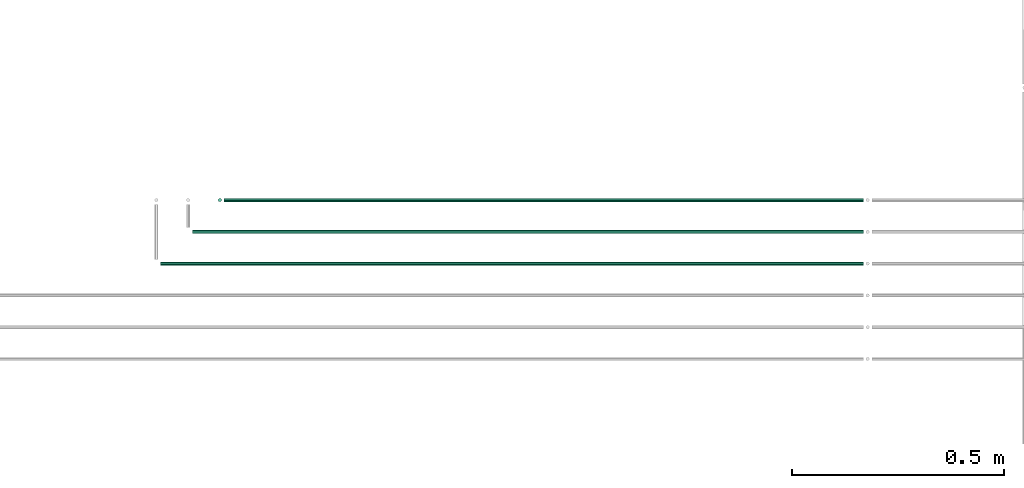
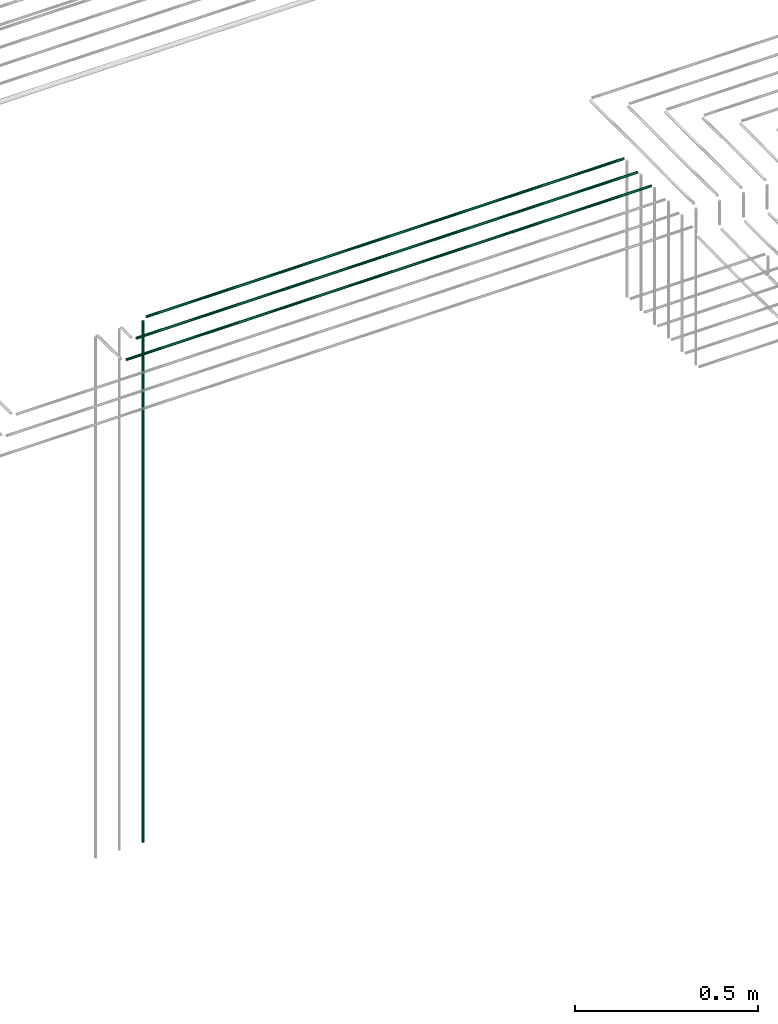
# One storey, part 23 of 89: 4 flow segments.
"""IFC2X3 building model written with IfcOpenShell, lengths in millimetres."""

from ifc_helpers import new_model, entity, si_unit, converted_unit, derived_unit, direction, frame, frame_2d, origin, origin_2d_with_axis, place, context, subcontext, project, spatial, circle, extrude, type_object, element, save


model = new_model("IFC2X3")

# Units and contexts
model_context = context("Model", 3, precision=0.01, world=origin(), true_north=direction((6.12303176911189e-17, 1.0)))
body_context = subcontext(model_context, "Body", "Model", "MODEL_VIEW")
ifc_project = project(units=[si_unit("LENGTHUNIT", "METRE", prefix="MILLI"), si_unit("AREAUNIT", "SQUARE_METRE"), si_unit("VOLUMEUNIT", "CUBIC_METRE"), converted_unit("PLANEANGLEUNIT", "DEGREE", entity("IfcRatioMeasure", 0.0174532925199433), si_unit("PLANEANGLEUNIT", "RADIAN"), dimensions=[0, 0, 0, 0, 0, 0, 0]), si_unit("MASSUNIT", "GRAM", prefix="KILO"), derived_unit("MASSDENSITYUNIT", [(si_unit("MASSUNIT", "GRAM", prefix="KILO"), 1), (si_unit("LENGTHUNIT", "METRE"), -3)]), derived_unit("MOMENTOFINERTIAUNIT", [(si_unit("LENGTHUNIT", "METRE"), 4)]), si_unit("TIMEUNIT", "SECOND"), si_unit("FREQUENCYUNIT", "HERTZ"), si_unit("THERMODYNAMICTEMPERATUREUNIT", "DEGREE_CELSIUS"), derived_unit("THERMALTRANSMITTANCEUNIT", [(si_unit("MASSUNIT", "GRAM", prefix="KILO"), 1), (si_unit("THERMODYNAMICTEMPERATUREUNIT", "KELVIN"), -1), (si_unit("TIMEUNIT", "SECOND"), -3)]), derived_unit("VOLUMETRICFLOWRATEUNIT", [(si_unit("LENGTHUNIT", "METRE"), 3), (si_unit("TIMEUNIT", "SECOND"), -1)]), derived_unit("MASSFLOWRATEUNIT", [(si_unit("MASSUNIT", "GRAM", prefix="KILO"), 1), (si_unit("TIMEUNIT", "SECOND"), -1)]), derived_unit("ROTATIONALFREQUENCYUNIT", [(si_unit("TIMEUNIT", "SECOND"), -1)]), si_unit("ELECTRICCURRENTUNIT", "AMPERE"), si_unit("ELECTRICVOLTAGEUNIT", "VOLT"), si_unit("POWERUNIT", "WATT"), si_unit("FORCEUNIT", "NEWTON", prefix="KILO"), si_unit("ILLUMINANCEUNIT", "LUX"), si_unit("LUMINOUSFLUXUNIT", "LUMEN"), si_unit("LUMINOUSINTENSITYUNIT", "CANDELA"), derived_unit("USERDEFINED", [(si_unit("MASSUNIT", "GRAM", prefix="KILO"), -1), (si_unit("LENGTHUNIT", "METRE"), -2), (si_unit("TIMEUNIT", "SECOND"), 3), (si_unit("LUMINOUSFLUXUNIT", "LUMEN"), 1)]), derived_unit("LINEARVELOCITYUNIT", [(si_unit("LENGTHUNIT", "METRE"), 1), (si_unit("TIMEUNIT", "SECOND"), -1)]), si_unit("PRESSUREUNIT", "PASCAL"), derived_unit("USERDEFINED", [(si_unit("LENGTHUNIT", "METRE"), -2), (si_unit("MASSUNIT", "GRAM", prefix="KILO"), 1), (si_unit("TIMEUNIT", "SECOND"), -2)]), derived_unit("LINEARFORCEUNIT", [(si_unit("MASSUNIT", "GRAM", prefix="KILO"), 1), (si_unit("LENGTHUNIT", "METRE"), 1), (si_unit("TIMEUNIT", "SECOND"), -2), (si_unit("LENGTHUNIT", "METRE"), -1)]), derived_unit("PLANARFORCEUNIT", [(si_unit("MASSUNIT", "GRAM", prefix="KILO"), 1), (si_unit("LENGTHUNIT", "METRE"), 1), (si_unit("TIMEUNIT", "SECOND"), -2), (si_unit("LENGTHUNIT", "METRE"), -2)])], contexts=[model_context])

# Site, building, storey
site_placement = place(None, frame((0.0, -0.00077364408347762, 0.0)))
site = spatial("IfcSite", under=ifc_project, at=site_placement, CompositionType="ELEMENT")
building_placement = place(site_placement, origin())
building = spatial("IfcBuilding", under=site, at=building_placement, CompositionType="ELEMENT")
storey_placement = place(building_placement, frame((0.0, 0.0, 24000.0)))
storey = spatial("IfcBuildingStorey", under=building, at=storey_placement, CompositionType="ELEMENT", Elevation=24000.0)

# Flow segments
pipe_segment_type = type_object("IfcPipeSegmentType", PredefinedType="NOTDEFINED")
flow_segment_1_placement = place(storey_placement, frame((65690.5981151137, 8369.3939590899, 1400.0)))
element("IfcFlowSegment", 1, at=flow_segment_1_placement, inside=storey, type_object=pipe_segment_type, context=body_context, shape_type="SweptSolid", body=[
    extrude(circle(Radius=4.0, at=frame_2d((0.0, -1.08286712929839e-12), x_axis=(1.0, 0.0))), frame((5.59527223591499, 5.59527223591716, 0.0)), (0.0, 0.0, 1.0), 1740.0),
])
flow_segment_2_placement = place(storey_placement, frame((65706.1933873496, 8369.3939590899, 3144.40472776409)))
element("IfcFlowSegment", 2, at=flow_segment_2_placement, inside=storey, type_object=pipe_segment_type, context=body_context, shape_type="SweptSolid", body=[
    extrude(circle(Radius=4.0, at=origin_2d_with_axis()), frame((0.0, 5.59527223591607, 5.59527223591499), z_axis=(1.0, 0.0, 0.0), x_axis=(0.0, -1.0, 0.0)), (0.0, 0.0, 1.0), 1508.91849592804),
])
flow_segment_3_placement = place(storey_placement, frame((65631.1933873496, 8294.39395908988, 3144.40472776409)))
element("IfcFlowSegment", 3, at=flow_segment_3_placement, inside=storey, type_object=pipe_segment_type, context=body_context, shape_type="SweptSolid", body=[
    extrude(circle(Radius=4.0, at=origin_2d_with_axis()), frame((0.0, 5.59527223591607, 5.59527223591499), z_axis=(1.0, 0.0, 0.0), x_axis=(0.0, -1.0, 0.0)), (0.0, 0.0, 1.0), 1583.91849592804),
])
flow_segment_4_placement = place(storey_placement, frame((65556.1938458084, 8219.39395908987, 3144.40472776409)))
element("IfcFlowSegment", 4, at=flow_segment_4_placement, inside=storey, type_object=pipe_segment_type, context=body_context, shape_type="SweptSolid", body=[
    extrude(circle(Radius=4.0, at=origin_2d_with_axis()), frame((0.0, 5.59527223591607, 5.59527223591499), z_axis=(1.0, 0.0, 0.0), x_axis=(0.0, -1.0, 0.0)), (0.0, 0.0, 1.0), 1658.91803746927),
])

save(model, "model.ifc")
